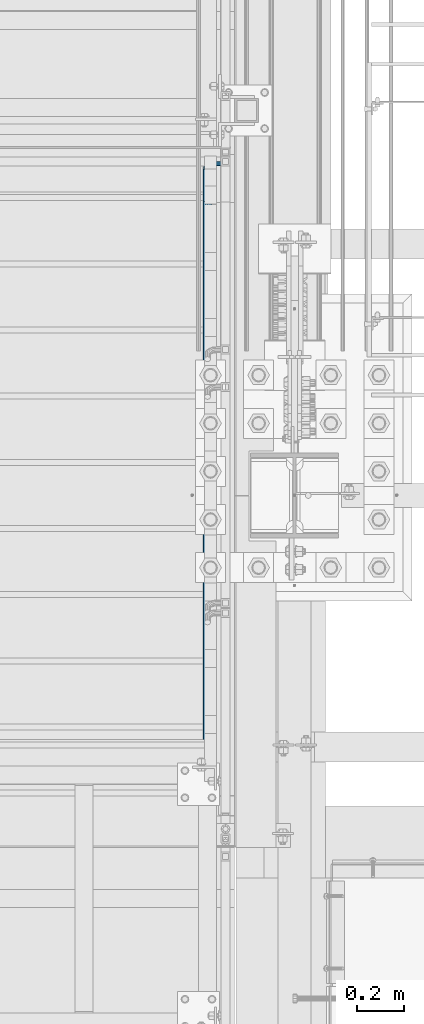
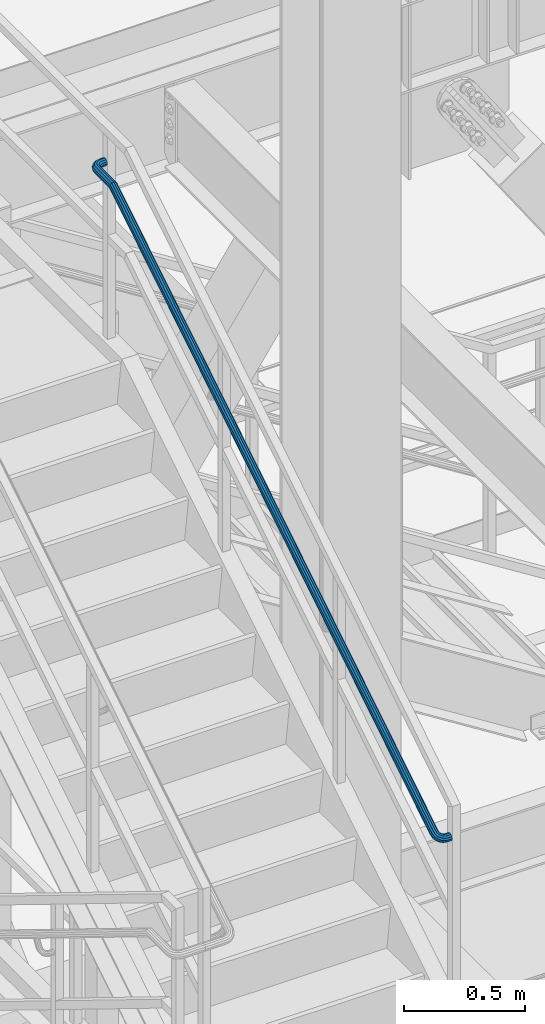
# One storey, part 1770 of 3843: 1 beam, 1 element without a shape of its own.
"""IFC2X3 building model written with IfcOpenShell, lengths in millimetres."""

from ifc_helpers import new_model, si_unit, frame, origin_with_axes, place, context, subcontext, project, spatial, faceted_brep, material, type_object, element, aggregate, save


model = new_model("IFC2X3")

# Units and contexts
model_context = context("Model", 3, precision=1e-05, world=origin_with_axes())
body_context = subcontext(model_context, "Body", "Model", "MODEL_VIEW")
ifc_project = project(units=[si_unit("LENGTHUNIT", "METRE", prefix="MILLI"), si_unit("AREAUNIT", "SQUARE_METRE"), si_unit("VOLUMEUNIT", "CUBIC_METRE"), si_unit("MASSUNIT", "GRAM", prefix="KILO"), si_unit("TIMEUNIT", "SECOND"), si_unit("PLANEANGLEUNIT", "RADIAN"), si_unit("SOLIDANGLEUNIT", "STERADIAN"), si_unit("THERMODYNAMICTEMPERATUREUNIT", "DEGREE_CELSIUS"), si_unit("LUMINOUSINTENSITYUNIT", "LUMEN")], contexts=[model_context])

# Site, building, storey
site_placement = place(None, origin_with_axes())
site = spatial("IfcSite", under=ifc_project, at=site_placement, CompositionType="ELEMENT")
building_placement = place(site_placement, origin_with_axes())
building = spatial("IfcBuilding", under=site, at=building_placement, Name="Undefined", CompositionType="ELEMENT")
storey_placement = place(building_placement, origin_with_axes())
storey = spatial("IfcBuildingStorey", under=building, at=storey_placement, Name="Undefined", CompositionType="ELEMENT", Elevation=0.0)

# Assembly, beam
assembly_placement = place(storey_placement, origin_with_axes())
assembly = element("IfcElementAssembly", 1, at=assembly_placement, inside=storey, Name="RAIL", AssemblyPlace="NOTDEFINED", PredefinedType="RIGID_FRAME")
ifc_material = material(Name="STEEL/A513")
beam_type = type_object("IfcBeamType", PredefinedType="NOTDEFINED")
beam_placement = place(assembly_placement, frame((55619.65, 18859.5000010295, 35928.2230266372), z_axis=(0.0, 0.0, 1.0), x_axis=(-1.0, 0.0, 0.0)))
beam = element("IfcBeam", 2, at=beam_placement, type_object=beam_type, material=ifc_material, Name="GRAB RAIL", context=body_context, shape_type="Brep", body=[
    faceted_brep([(0.0, -19.0500000000029, 0.0), (0.0, -16.4977839420972, -9.52500000000146), (19.0500015258804, -16.4977839420972, -9.52500000000146), (19.0500015258804, -19.0500000000029, 0.0), (0.0, -9.52500000000146, -16.4977839420972), (19.0500015258804, -9.52500000000146, -16.4977839420972), (0.0, 0.0, -19.0499989999989), (19.0500015258804, 0.0, -19.0500000000029), (0.0, 9.52500000000146, -16.4977839420972), (19.0500015258804, 9.52500000000146, -16.4977839420972), (0.0, 16.4977839420972, -9.52500000000146), (19.0500015258804, 16.4977839420972, -9.52500000000146), (0.0, 19.0500000000029, 0.0), (19.0500015258804, 19.0500000000029, 0.0), (0.0, 16.4977839420972, 9.52500000000146), (19.0500015258804, 16.4977839420972, 9.52500000000146), (0.0, 9.52500000000146, 16.4977839420972), (19.0500015258804, 9.52500000000146, 16.4977839420972), (0.0, 0.0, 19.0499989999989), (19.0500015258804, 0.0, 19.0500000000029), (0.0, -9.52500000000146, 16.4977839420972), (19.0500015258804, -9.52500000000146, 16.4977839420972), (0.0, -16.4977839420972, 9.52500000000146), (19.0500015258804, -16.4977839420972, 9.52500000000146), (0.0, -15.875, 0.0), (0.0, -13.7481532850798, 7.9375), (19.0500015258804, -13.7481532850798, 7.9375), (19.0500015258804, -15.875, 0.0), (0.0, -7.9375, 13.7481532850798), (19.0500015258804, -7.9375, 13.7481532850798), (0.0, 0.0, 15.875), (19.0500015258804, 0.0, 15.875), (0.0, 7.9375, 13.7481532850798), (19.0500015258804, 7.9375, 13.7481532850798), (0.0, 13.7481532850798, 7.9375), (19.0500015258804, 13.7481532850798, 7.9375), (0.0, 15.875, 0.0), (19.0500015258804, 15.875, 0.0), (0.0, 13.7481532850798, -7.9375), (19.0500015258804, 13.7481532850798, -7.9375), (0.0, 7.9375, -13.7481532850798), (19.0500015258804, 7.9375, -13.7481532850798), (0.0, 0.0, -15.875), (19.0500015258804, 0.0, -15.875), (0.0, -7.9375, -13.7481532850798), (19.0500015258804, -7.9375, -13.7481532850798), (0.0, -13.7481532850798, -7.9375), (19.0500015258804, -13.7481532850798, -7.9375), (25.8298748692396, -19.9609130194985, 0.568630552115792), (24.9402688023329, -17.2891735269295, 10.0190189534405), (25.6270827899934, -10.4086667958763, 17.0494062455109), (27.7062855788754, -1.16301904843931, 19.7760058309432), (30.6207564607903, 7.97040586794901, 17.4682275527448), (33.5895653165717, 14.544314122817, 10.7444387368523), (35.817222210826, 16.7972323081558, 1.40627316657628), (36.7068282777327, 14.1254928155868, -8.04411523474118), (36.0200142900721, 7.24498608453359, -15.0745025268116), (33.9408115011975, -2.0006616628998, -17.8011021122438), (31.0263406192753, -11.1340865792918, -15.4933238340454), (28.0575317634939, -17.7079948341598, -8.76953501816024), (35.7262816547809, 11.5076039537125, -6.53885405239271), (34.9849432656993, 13.7340535308504, 1.33646961537306), (33.1285625204837, 11.8566217097359, 9.11827425727097), (30.6545551406598, 6.37836483067804, 14.7214316038444), (28.2258294057319, -1.23282259964617, 16.6445801690134), (26.4931604150042, -8.93752905584188, 14.3724138478137), (25.9208154252847, -14.6712846650553, 8.51375777109206), (26.6621538143736, -16.8977342421931, 0.63843410332629), (28.5185345595892, -15.0203024210787, -7.14337053857162), (30.9925419394058, -9.54204554202079, -12.746527885145), (33.4212676743336, -1.93085811169658, -14.669676450314), (35.1539366650686, 5.77384834449913, -12.3975101291217), (46.7058953003507, 8.8751239015146, 14.283387787531), (50.9431505110551, 10.2594458302447, 5.48743685069348), (41.0588852844958, 3.4587979769276, 20.2845646025962), (35.5152322368958, -4.53823178607854, 21.8829568146684), (31.5603535147675, -12.9731677206655, 18.6502765213299), (30.2539556778793, -19.5858755549489, 11.4527177965647), (31.9460869716058, -22.6044855649452, 2.21886068815365), (36.1833421823176, -21.2201636362188, -6.57709024868382), (41.8303521981725, -15.8038377116318, -12.5782670637491), (47.3740052457724, -7.80680794862201, -14.1766592758213), (51.3288839678935, 0.628127985964966, -10.9439789824828), (52.635281804789, 7.24083582024468, -3.74642025771755), (49.6815064301336, -0.50531332292303, -8.47779102382628), (50.7701712942144, 5.00527653898098, -2.4798254198613), (46.3857741616957, -7.53442660174187, -11.1716912682823), (41.7660632886982, -14.1986180709173, -9.83969775822334), (37.0602216088155, -18.7122230080713, -4.83871707900107), (33.5291755998915, -19.8658246153464, 2.49124203503015), (32.1190661884539, -17.3503162736815, 10.1861229587084), (33.2077310525274, -11.8397264117812, 16.1840885626807), (36.5034633209652, -4.81061313295868, 18.8779888071294), (41.12317419397, 1.85357833621674, 17.5459952970705), (45.8290158738455, 6.36718327337076, 12.5450146178482), (49.3600618827695, 7.52078488064581, 5.21505550381698), (57.115073711524, 0.0451531166363566, 19.7954301616264), (62.9471551759634, 0.0766046581811679, 11.843998315795), (49.3426312209849, -3.56819605845521, 24.6711123986461), (41.7124473929071, -9.79524887365551, 25.1646099088903), (36.2690238221185, -16.9674715559122, 21.1436904330258), (34.47092145848, -23.1630728295713, 13.6857560974386), (36.7999403782305, -26.7219463367328, 4.78915438455442), (42.6320218426699, -26.6904947951916, -3.16227746127697), (50.4044643332018, -23.0771456201001, -8.03795969829662), (58.0346481612869, -16.8500928048961, -8.53145720854081), (63.4780717320682, -9.67787012263943, -4.51053773267631), (65.2761740957139, -3.48226884898395, 2.94739660291089), (61.2106510729063, -10.2853369087461, -2.37268538553326), (62.709069709279, -5.12233584736532, 3.84225989411789), (56.6744647639207, -16.2621891439594, -5.72345161542034), (50.3159782405201, -21.4513998232942, -5.31220369022049), (43.8389428317387, -24.4625241358699, -1.24913515937078), (38.9788749447034, -24.4887337538239, 5.3770580454875), (37.038025844915, -21.5230058311863, 12.7908928062243), (38.5364444812803, -16.3600047698055, 19.0058380858827), (43.072630790266, -10.3831525345922, 22.3566043157698), (49.4311173136666, -5.19394185525744, 21.9453563905699), (55.908152722448, -2.18281754268173, 17.8822878597202), (60.7682206094833, -2.15660792472772, 11.2560946548547), (63.7981776422239, -11.0812591693903, 26.7410087469252), (70.654200592151, -12.7545237661107, 19.8537330369218), (54.6611235017626, -12.4227251020857, 30.198485079738), (45.691304448912, -16.4194768508569, 29.2997340441289), (39.2921762551268, -22.0005880122771, 24.2855752542891), (37.1783801522106, -27.6706043577688, 16.4995485086838), (39.9163060988867, -31.91024958649, 8.02791338603129), (46.7723290488211, -33.5835141832104, 1.14063767602784), (55.9093831892824, -32.2420482505149, -2.31683865678497), (64.879202242133, -28.2452965017437, -1.4180876211758), (71.2783304359109, -22.6641853403235, 3.59607116865664), (73.3921265388344, -16.9941689948319, 11.3820979142693), (68.6128175875128, -22.608885562986, 5.32019650912844), (70.3743143399479, -17.8838719417436, 11.8085521304747), (63.280210759367, -27.2598115308356, 1.14173085093353), (55.8053615486569, -30.5904379881467, 0.392771654594981), (48.1911497649344, -31.7083262653941, 3.27400193193898), (42.4777973066593, -30.3139391014593, 9.01339835693943), (40.1961923510971, -26.780901410857, 16.0730942924783), (41.9576891035249, -22.0558877896146, 22.5614499138246), (47.290295931678, -17.404961821765, 26.7399155720195), (54.7651451423881, -14.0743353644539, 27.4888747683581), (62.3793569261034, -12.9564470872065, 24.6076444910141), (68.0927093843784, -14.3508342511414, 18.8682480660136), (57.806248953726, -42.401421077775, 4.02507287184562), (48.1989816842106, -41.2244850360839, 5.91045584942913), (67.237674846052, -40.8769771062507, 6.46714330929535), (73.9661164098725, -37.0596266525899, 12.5823163601963), (76.1886931618355, -31.9722256880741, 20.7320363439794), (73.3098674561406, -26.9779391927186, 28.7325923724566), (66.1010183157778, -23.4149821997271, 34.4402419187973), (56.4937510462623, -22.238046158036, 36.3256248963735), (47.0623251539364, -23.7624901295603, 33.8835544589238), (40.3338835901159, -27.5798405832211, 27.7683814080228), (38.1113068381528, -32.6672415477406, 19.6186614242397), (40.9901325438477, -37.6615280430924, 11.6181053957625), (71.1634303415558, -36.2696444801404, 13.8478217808515), (73.015577634862, -32.0301436763766, 20.639255100672), (65.5563957050472, -39.4507698581947, 8.75184423843166), (57.6968741281016, -40.7211398344662, 6.71678554055688), (49.6908180701794, -39.7403597997218, 8.28793802187283), (43.68344378654, -36.7712289722294, 13.0443126438186), (41.2844223651264, -32.6093235594344, 19.7114426675471), (43.1365696584326, -28.3698227556706, 26.5028759873676), (48.7436042949412, -25.1886973776163, 31.5988535297874), (56.6031258718867, -23.9183274013485, 33.6339122276622), (64.609181929809, -24.8991074360893, 32.0627597463463), (70.6165562134483, -27.8682382635816, 27.3063851244005), (48.1989816842106, -2696.25353190033, 1663.29222610786), (40.9901325438477, -2692.69057490734, 1668.9998756542), (57.806248953726, -2697.43046794202, 1661.40684313028), (67.237674846052, -2695.9060239705, 1663.84891356773), (73.9661164098725, -2692.08867351683, 1669.96408661863), (76.1886931618355, -2687.00127255231, 1678.11380660241), (73.3098674561406, -2682.00698605696, 1686.11436263089), (66.1010183157778, -2678.44402906396, 1691.82201217723), (56.4937510462623, -2677.26709302227, 1693.70739515481), (47.0623251539364, -2678.7915369938, 1691.26532471736), (40.3338835901159, -2682.60888744746, 1685.15015166646), (38.1113068381528, -2687.69628841198, 1677.00043168267), (41.2844223651264, -2687.63837042368, 1677.09321292599), (43.68344378654, -2691.80027583647, 1670.42608290225), (43.1365696584326, -2683.39886961991, 1683.88464624581), (48.7436042949412, -2680.21774424186, 1688.98062378822), (56.6031258718867, -2678.94737426559, 1691.0156824861), (64.609181929809, -2679.92815430033, 1689.44453000478), (70.6165562134483, -2682.89728512782, 1684.68815538284), (73.015577634862, -2687.05919054062, 1678.02102535911), (71.1634303415558, -2691.29869134438, 1671.22959203928), (65.5563957050472, -2694.47981672244, 1666.13361449687), (57.6968741281016, -2695.75018669871, 1664.09855579899), (49.6908180701794, -2694.76940666396, 1665.66970828031), (48.1989816842106, -2697.2178401868, 1663.89418825091), (40.9901325438477, -2695.29013254061, 1670.62262981473), (57.806248953726, -2697.8546114448, 1661.67161149895), (67.237674846052, -2697.02982397028, 1664.55043720464), (73.9661164098725, -2694.96447890095, 1671.759286345), (76.1886931618355, -2692.21198378023, 1681.36655361452), (73.3098674561406, -2689.5098674529, 1690.79797950685), (66.1010183157778, -2687.58215980671, 1697.52642107067), (56.4937510462623, -2686.94538854871, 1699.74899782263), (47.0623251539364, -2687.77017602323, 1696.87017211693), (40.3338835901159, -2689.83552109256, 1689.66132297657), (38.1113068381528, -2692.58801621328, 1680.05405570706), (41.2844223651264, -2692.55668017719, 1680.16343053268), (43.68344378654, -2694.8084437833, 1672.30390895574), (43.1365696584326, -2690.26293424326, 1688.1694865906), (48.7436042949412, -2688.54181335216, 1694.17686087424), (56.6031258718867, -2687.85449045672, 1696.57588229566), (64.609181929809, -2688.38513317172, 1694.72373500236), (70.6165562134483, -2689.99155621021, 1689.11670036584), (73.015577634862, -2692.24331981632, 1681.2571787889), (71.1634303415558, -2694.53706575025, 1673.25112273097), (65.5563957050472, -2696.25818664136, 1667.24374844733), (57.6968741281016, -2696.9455095368, 1664.84472702592), (49.6908180701794, -2696.41486682179, 1666.69687431922), (48.1989816842106, -2698.3546114448, 1663.89418825091), (40.9901325438477, -2698.3546114448, 1670.62262981473), (57.806248953726, -2698.3546114448, 1661.67161149895), (67.237674846052, -2698.3546114448, 1664.55043720464), (73.9661164098725, -2698.3546114448, 1671.75928634501), (76.1886931618355, -2698.3546114448, 1681.36655361452), (73.3098674561406, -2698.3546114448, 1690.79797950685), (66.1010183157778, -2698.3546114448, 1697.52642107067), (56.4937510462623, -2698.3546114448, 1699.74899782263), (47.0623251539364, -2698.3546114448, 1696.87017211693), (40.3338835901159, -2698.3546114448, 1689.66132297656), (38.1113068381528, -2698.3546114448, 1680.05405570706), (41.2844223651264, -2698.3546114448, 1680.16343053267), (43.68344378654, -2698.3546114448, 1672.30390895574), (43.1365696584326, -2698.3546114448, 1688.1694865906), (48.7436042949412, -2698.3546114448, 1694.17686087424), (56.6031258718795, -2698.3546114448, 1696.57588229566), (64.609181929809, -2698.3546114448, 1694.72373500235), (70.6165562134483, -2698.3546114448, 1689.11670036584), (73.015577634862, -2698.3546114448, 1681.2571787889), (71.1634303415558, -2698.3546114448, 1673.25112273097), (65.5563957050472, -2698.3546114448, 1667.24374844733), (57.6968741281089, -2698.3546114448, 1664.84472702592), (49.6908180701794, -2698.3546114448, 1666.69687431923), (48.1989816842106, -2819.40000050106, 1663.89418825091), (40.990132543855, -2819.40000050106, 1670.62262981472), (57.806248953726, -2819.40000050106, 1661.67161149895), (67.237674846052, -2819.40000050106, 1664.55043720464), (73.9661164098725, -2819.40000050106, 1671.75928634501), (76.1886931618355, -2819.40000050106, 1681.36655361452), (73.3098674561406, -2819.40000050106, 1690.79797950685), (66.1010183157778, -2819.40000050106, 1697.52642107067), (56.4937510462623, -2819.40000050106, 1699.74899782263), (47.0623251539364, -2819.40000050106, 1696.87017211693), (40.3338835901159, -2819.40000050106, 1689.66132297656), (38.1113068381528, -2819.40000050106, 1680.05405570706), (41.2844223651264, -2819.40000050106, 1680.16343053267), (43.68344378654, -2819.40000050106, 1672.30390895574), (43.1365696584326, -2819.40000050106, 1688.1694865906), (48.7436042949412, -2819.40000050106, 1694.17686087424), (56.6031258718795, -2819.40000050106, 1696.57588229566), (64.609181929809, -2819.40000050106, 1694.72373500235), (70.6165562134483, -2819.40000050106, 1689.11670036584), (73.015577634862, -2819.40000050106, 1681.2571787889), (71.1634303415558, -2819.40000050106, 1673.25112273097), (65.5563957050472, -2819.40000050106, 1667.24374844733), (57.6968741281089, -2819.40000050106, 1664.84472702592), (49.6908180701794, -2819.40000050106, 1666.69687431923), (39.9163060988867, -2826.17987384443, 1670.62262981472), (37.1783801522106, -2825.29026777753, 1680.05405570705), (39.2921762551341, -2825.97708176519, 1689.66132297656), (45.691304448912, -2828.05628455407, 1696.87017211693), (54.6611235017626, -2830.97075543599, 1699.74899782263), (63.7981776422239, -2833.93956429177, 1697.52642107067), (70.654200592151, -2836.16722118603, 1690.79797950685), (73.3921265388271, -2837.05682725293, 1681.36655361453), (71.2783304359109, -2836.37001326527, 1671.75928634502), (64.8792022421258, -2834.29081047639, 1664.55043720465), (55.9093831892751, -2831.37633959447, 1661.67161149895), (46.7723290488211, -2828.40753073869, 1663.89418825091), (70.3743143399479, -2836.07628062998, 1681.2571787889), (68.0927093843784, -2835.3349422409, 1689.11670036584), (62.3793569261034, -2833.47856149568, 1694.72373500236), (54.7651451423953, -2831.00455411587, 1696.57588229566), (47.2902959316853, -2828.57582838093, 1694.17686087424), (41.9576891035322, -2826.8431593902, 1688.1694865906), (40.1961923510971, -2826.27081440048, 1680.16343053267), (42.4777973066593, -2827.01215278957, 1672.30390895574), (48.1911497649344, -2828.86853353478, 1666.69687431923), (55.8053615486497, -2831.3425409146, 1664.84472702593), (63.2802107593598, -2833.77126664953, 1667.24374844734), (68.6128175875128, -2835.50393564026, 1673.25112273098), (57.115073711524, -2847.05589427555, 1697.52642107067), (62.9471551759634, -2851.29314948625, 1690.79797950685), (49.3426312209922, -2841.4088842597, 1699.74899782263), (41.7124473929071, -2835.8652312121, 1696.87017211693), (36.2690238221257, -2831.91035248997, 1689.66132297656), (34.47092145848, -2830.60395465308, 1680.05405570706), (36.7999403782305, -2832.2960859468, 1670.62262981473), (42.6320218426699, -2836.53334115751, 1663.89418825091), (50.4044643332018, -2842.18035117336, 1661.67161149895), (58.0346481612869, -2847.72400422096, 1664.55043720465), (63.4780717320682, -2851.67888294308, 1671.75928634502), (65.2761740957139, -2852.98528077998, 1681.36655361453), (61.2106510729063, -2850.03150540532, 1673.25112273098), (62.709069709279, -2851.12017026941, 1681.2571787889), (56.6744647639207, -2846.73577313689, 1667.24374844734), (50.3159782405201, -2842.11606226389, 1664.84472702593), (43.8389428317387, -2837.41022058401, 1666.69687431923), (38.9788749447107, -2833.87917457509, 1672.30390895574), (37.038025844915, -2832.46906516365, 1680.16343053267), (38.5364444812876, -2833.55773002773, 1688.1694865906), (43.0726307902733, -2836.85346229617, 1694.17686087424), (49.4311173136739, -2841.47317316917, 1696.57588229566), (55.9081527224553, -2846.17901484904, 1694.72373500236), (60.7682206094833, -2849.71006085797, 1689.11670036584), (46.7058953003434, -2857.46507268674, 1697.52642107067), (50.9431505110479, -2863.29715415117, 1690.79797950685), (41.0588852844885, -2849.6926301962, 1699.74899782263), (35.5152322368958, -2842.06244636812, 1696.87017211693), (31.5603535147675, -2836.61902279733, 1689.66132297657), (30.2539556778793, -2834.82092043368, 1680.05405570706), (31.9460869716058, -2837.14993935343, 1670.62262981473), (36.1833421823103, -2842.98202081787, 1663.89418825092), (41.8303521981579, -2850.7544633084, 1661.67161149895), (47.3740052457579, -2858.38464713649, 1664.55043720465), (51.3288839678862, -2863.82807070727, 1671.75928634502), (52.6352818047744, -2865.62617307092, 1681.36655361453), (49.6815064301263, -2861.56065004811, 1673.25112273098), (50.7701712941998, -2863.05906868448, 1681.25717878891), (46.3857741616885, -2857.02446373912, 1667.24374844734), (41.7660632886909, -2850.66597721572, 1664.84472702593), (37.0602216088082, -2844.18894180694, 1666.69687431923), (33.5291755998915, -2839.32887391991, 1672.30390895574), (32.1190661884539, -2837.38802482012, 1680.16343053268), (33.2077310525274, -2838.88644345649, 1688.1694865906), (36.5034633209652, -2843.42262976548, 1694.17686087424), (41.1231741939628, -2849.78111628888, 1696.57588229566), (45.8290158738382, -2856.25815169766, 1694.72373500236), (49.3600618827622, -2861.11821958469, 1689.11670036584), (33.5895653165644, -2864.14817661744, 1697.52642107067), (35.8172222108187, -2871.00419956737, 1690.79797950685), (30.620756460783, -2855.01112247698, 1699.74899782263), (27.7062855788681, -2846.04130342413, 1696.87017211693), (25.6270827899934, -2839.64217523034, 1689.66132297657), (24.9402688023329, -2837.52837912742, 1680.05405570706), (25.8298748692323, -2840.2663050741, 1670.62262981473), (28.0575317634939, -2847.12232802402, 1663.89418825092), (31.026340619268, -2856.25938216448, 1661.67161149895), (33.9408115011902, -2865.22920121733, 1664.55043720465), (36.0200142900649, -2871.62832941112, 1671.75928634502), (36.7068282777254, -2873.74212551404, 1681.36655361453), (35.1539366650613, -2868.96281656272, 1673.25112273098), (35.7262816547736, -2870.72431331516, 1681.25717878891), (33.4212676743264, -2863.63020973457, 1667.24374844734), (30.9925419393985, -2856.15536052386, 1664.84472702593), (28.5185345595819, -2848.54114874014, 1666.69687431923), (26.6621538143663, -2842.82779628187, 1672.30390895574), (25.9208154252774, -2840.5461913263, 1680.16343053268), (26.493160414997, -2842.30768807874, 1688.16948659061), (28.2258294057319, -2847.64029490689, 1694.17686087424), (30.6545551406598, -2855.11514411761, 1696.57588229566), (33.1285625204764, -2862.72935590132, 1694.72373500236), (34.9849432656847, -2868.4427083596, 1689.11670036585), (19.0500015258731, -2858.15624792893, 1661.67161149895), (19.0500015258658, -2848.54898065942, 1663.89418825092), (19.0500015258731, -2867.58767382126, 1664.55043720466), (19.0500015258731, -2874.31611538508, 1671.75928634502), (19.0500015258658, -2876.53869213705, 1681.36655361453), (19.0500015258658, -2873.65986643136, 1690.79797950685), (19.0500015258585, -2866.45101729099, 1697.52642107067), (19.0500015258585, -2856.84375002148, 1699.74899782264), (19.0500015258585, -2847.41232412916, 1696.87017211693), (19.0500015258658, -2840.68388256533, 1689.66132297657), (19.0500015258658, -2838.46130581337, 1680.05405570706), (19.0500015258731, -2841.34013151904, 1670.62262981473), (19.0500015258658, -2871.51342931676, 1673.25112273098), (19.0500015258658, -2873.36557661007, 1681.25717878891), (19.0500015258731, -2865.90639468025, 1667.24374844734), (19.0500015258731, -2858.04687310331, 1664.84472702593), (19.0500015258658, -2850.04081704538, 1666.69687431923), (19.0500015258731, -2844.03344276173, 1672.30390895574), (19.0500015258658, -2841.63442134034, 1680.16343053269), (19.0500015258658, -2843.48656863365, 1688.16948659061), (19.0500015258585, -2849.09360327016, 1694.17686087425), (19.0500015258585, -2856.9531248471, 1696.57588229566), (19.0500015258585, -2864.95918090503, 1694.72373500236), (19.0500015258658, -2870.96655518866, 1689.11670036585), (0.0, -2848.5489806594, 1663.89418825091), (0.0, -2841.34013151904, 1670.62262981473), (0.0, -2858.15624792892, 1661.67161149895), (0.0, -2867.58767382124, 1664.55043720464), (0.0, -2874.31611538506, 1671.75928634501), (0.0, -2876.53869213702, 1681.36655361452), (0.0, -2873.65986643132, 1690.79797950685), (0.0, -2866.45101729096, 1697.52642107067), (0.0, -2856.84375002145, 1699.74899782263), (0.0, -2847.41232412912, 1696.87017211693), (0.0, -2840.6838825653, 1689.66132297656), (0.0, -2838.46130581334, 1680.05405570706), (0.0, -2841.63442134031, 1680.16343053267), (0.0, -2844.03344276173, 1672.30390895574), (0.0, -2843.48656863362, 1688.1694865906), (0.0, -2849.09360327013, 1694.17686087424), (0.0, -2856.95312484707, 1696.57588229566), (0.0, -2864.959180905, 1694.72373500235), (0.0, -2870.96655518864, 1689.11670036584), (0.0, -2873.36557661005, 1681.2571787889), (0.0, -2871.51342931675, 1673.25112273097), (0.0, -2865.90639468023, 1667.24374844733), (0.0, -2858.04687310329, 1664.84472702592), (0.0, -2850.04081704537, 1666.69687431923)], [[[0, 1, 2, 3]], [[1, 4, 5, 2]], [[4, 6, 7, 5]], [[6, 8, 9, 7]], [[8, 10, 11, 9]], [[10, 12, 13, 11]], [[12, 14, 15, 13]], [[14, 16, 17, 15]], [[16, 18, 19, 17]], [[18, 20, 21, 19]], [[20, 22, 23, 21]], [[22, 0, 3, 23]], [[24, 25, 26, 27]], [[25, 28, 29, 26]], [[28, 30, 31, 29]], [[30, 32, 33, 31]], [[32, 34, 35, 33]], [[34, 36, 37, 35]], [[36, 38, 39, 37]], [[38, 40, 41, 39]], [[40, 42, 43, 41]], [[42, 44, 45, 43]], [[44, 46, 47, 45]], [[46, 24, 27, 47]], [[22, 20, 18, 16, 14, 12, 10, 8, 6, 4, 1, 0], [46, 44, 42, 40, 38, 36, 34, 32, 30, 28, 25, 24]], [[23, 3, 48, 49]], [[21, 23, 49, 50]], [[19, 21, 50, 51]], [[17, 19, 51, 52]], [[15, 17, 52, 53]], [[13, 15, 53, 54]], [[11, 13, 54, 55]], [[9, 11, 55, 56]], [[7, 9, 56, 57]], [[5, 7, 57, 58]], [[2, 5, 58, 59]], [[3, 2, 59, 48]], [[37, 39, 60, 61]], [[35, 37, 61, 62]], [[33, 35, 62, 63]], [[31, 33, 63, 64]], [[29, 31, 64, 65]], [[26, 29, 65, 66]], [[27, 26, 66, 67]], [[47, 27, 67, 68]], [[45, 47, 68, 69]], [[43, 45, 69, 70]], [[41, 43, 70, 71]], [[39, 41, 71, 60]], [[53, 72, 73, 54]], [[52, 74, 72, 53]], [[51, 75, 74, 52]], [[50, 76, 75, 51]], [[49, 77, 76, 50]], [[48, 78, 77, 49]], [[59, 79, 78, 48]], [[58, 80, 79, 59]], [[57, 81, 80, 58]], [[56, 82, 81, 57]], [[55, 83, 82, 56]], [[54, 73, 83, 55]], [[71, 84, 85, 60]], [[70, 86, 84, 71]], [[69, 87, 86, 70]], [[68, 88, 87, 69]], [[67, 89, 88, 68]], [[66, 90, 89, 67]], [[65, 91, 90, 66]], [[64, 92, 91, 65]], [[63, 93, 92, 64]], [[62, 94, 93, 63]], [[61, 95, 94, 62]], [[60, 85, 95, 61]], [[72, 96, 97, 73]], [[74, 98, 96, 72]], [[75, 99, 98, 74]], [[76, 100, 99, 75]], [[77, 101, 100, 76]], [[78, 102, 101, 77]], [[79, 103, 102, 78]], [[80, 104, 103, 79]], [[81, 105, 104, 80]], [[82, 106, 105, 81]], [[83, 107, 106, 82]], [[73, 97, 107, 83]], [[84, 108, 109, 85]], [[86, 110, 108, 84]], [[87, 111, 110, 86]], [[88, 112, 111, 87]], [[89, 113, 112, 88]], [[90, 114, 113, 89]], [[91, 115, 114, 90]], [[92, 116, 115, 91]], [[93, 117, 116, 92]], [[94, 118, 117, 93]], [[95, 119, 118, 94]], [[85, 109, 119, 95]], [[96, 120, 121, 97]], [[98, 122, 120, 96]], [[99, 123, 122, 98]], [[100, 124, 123, 99]], [[101, 125, 124, 100]], [[102, 126, 125, 101]], [[103, 127, 126, 102]], [[104, 128, 127, 103]], [[105, 129, 128, 104]], [[106, 130, 129, 105]], [[107, 131, 130, 106]], [[97, 121, 131, 107]], [[108, 132, 133, 109]], [[110, 134, 132, 108]], [[111, 135, 134, 110]], [[112, 136, 135, 111]], [[113, 137, 136, 112]], [[114, 138, 137, 113]], [[115, 139, 138, 114]], [[116, 140, 139, 115]], [[117, 141, 140, 116]], [[118, 142, 141, 117]], [[119, 143, 142, 118]], [[109, 133, 143, 119]], [[128, 144, 145, 127]], [[129, 146, 144, 128]], [[130, 147, 146, 129]], [[131, 148, 147, 130]], [[121, 149, 148, 131]], [[120, 150, 149, 121]], [[122, 151, 150, 120]], [[123, 152, 151, 122]], [[124, 153, 152, 123]], [[125, 154, 153, 124]], [[126, 155, 154, 125]], [[127, 145, 155, 126]], [[132, 156, 157, 133]], [[134, 158, 156, 132]], [[135, 159, 158, 134]], [[136, 160, 159, 135]], [[137, 161, 160, 136]], [[138, 162, 161, 137]], [[139, 163, 162, 138]], [[140, 164, 163, 139]], [[141, 165, 164, 140]], [[142, 166, 165, 141]], [[143, 167, 166, 142]], [[133, 157, 167, 143]], [[155, 145, 168, 169]], [[145, 144, 170, 168]], [[144, 146, 171, 170]], [[146, 147, 172, 171]], [[147, 148, 173, 172]], [[148, 149, 174, 173]], [[149, 150, 175, 174]], [[150, 151, 176, 175]], [[151, 152, 177, 176]], [[152, 153, 178, 177]], [[153, 154, 179, 178]], [[154, 155, 169, 179]], [[161, 162, 180, 181]], [[162, 163, 182, 180]], [[163, 164, 183, 182]], [[164, 165, 184, 183]], [[165, 166, 185, 184]], [[166, 167, 186, 185]], [[167, 157, 187, 186]], [[157, 156, 188, 187]], [[156, 158, 189, 188]], [[158, 159, 190, 189]], [[159, 160, 191, 190]], [[160, 161, 181, 191]], [[169, 168, 192, 193]], [[168, 170, 194, 192]], [[170, 171, 195, 194]], [[171, 172, 196, 195]], [[172, 173, 197, 196]], [[173, 174, 198, 197]], [[174, 175, 199, 198]], [[175, 176, 200, 199]], [[176, 177, 201, 200]], [[177, 178, 202, 201]], [[178, 179, 203, 202]], [[179, 169, 193, 203]], [[181, 180, 204, 205]], [[180, 182, 206, 204]], [[182, 183, 207, 206]], [[183, 184, 208, 207]], [[184, 185, 209, 208]], [[185, 186, 210, 209]], [[186, 187, 211, 210]], [[187, 188, 212, 211]], [[188, 189, 213, 212]], [[189, 190, 214, 213]], [[190, 191, 215, 214]], [[191, 181, 205, 215]], [[193, 192, 216, 217]], [[192, 194, 218, 216]], [[194, 195, 219, 218]], [[195, 196, 220, 219]], [[196, 197, 221, 220]], [[197, 198, 222, 221]], [[198, 199, 223, 222]], [[199, 200, 224, 223]], [[200, 201, 225, 224]], [[201, 202, 226, 225]], [[202, 203, 227, 226]], [[203, 193, 217, 227]], [[205, 204, 228, 229]], [[204, 206, 230, 228]], [[206, 207, 231, 230]], [[207, 208, 232, 231]], [[208, 209, 233, 232]], [[209, 210, 234, 233]], [[210, 211, 235, 234]], [[211, 212, 236, 235]], [[212, 213, 237, 236]], [[213, 214, 238, 237]], [[214, 215, 239, 238]], [[215, 205, 229, 239]], [[217, 216, 240, 241]], [[216, 218, 242, 240]], [[218, 219, 243, 242]], [[219, 220, 244, 243]], [[220, 221, 245, 244]], [[221, 222, 246, 245]], [[222, 223, 247, 246]], [[223, 224, 248, 247]], [[224, 225, 249, 248]], [[225, 226, 250, 249]], [[226, 227, 251, 250]], [[227, 217, 241, 251]], [[229, 228, 252, 253]], [[228, 230, 254, 252]], [[230, 231, 255, 254]], [[231, 232, 256, 255]], [[232, 233, 257, 256]], [[233, 234, 258, 257]], [[234, 235, 259, 258]], [[235, 236, 260, 259]], [[236, 237, 261, 260]], [[237, 238, 262, 261]], [[238, 239, 263, 262]], [[239, 229, 253, 263]], [[251, 241, 264, 265]], [[250, 251, 265, 266]], [[249, 250, 266, 267]], [[248, 249, 267, 268]], [[247, 248, 268, 269]], [[246, 247, 269, 270]], [[245, 246, 270, 271]], [[244, 245, 271, 272]], [[243, 244, 272, 273]], [[242, 243, 273, 274]], [[240, 242, 274, 275]], [[241, 240, 275, 264]], [[258, 259, 276, 277]], [[257, 258, 277, 278]], [[256, 257, 278, 279]], [[255, 256, 279, 280]], [[254, 255, 280, 281]], [[252, 254, 281, 282]], [[253, 252, 282, 283]], [[263, 253, 283, 284]], [[262, 263, 284, 285]], [[261, 262, 285, 286]], [[260, 261, 286, 287]], [[259, 260, 287, 276]], [[269, 288, 289, 270]], [[268, 290, 288, 269]], [[267, 291, 290, 268]], [[266, 292, 291, 267]], [[265, 293, 292, 266]], [[264, 294, 293, 265]], [[275, 295, 294, 264]], [[274, 296, 295, 275]], [[273, 297, 296, 274]], [[272, 298, 297, 273]], [[271, 299, 298, 272]], [[270, 289, 299, 271]], [[287, 300, 301, 276]], [[286, 302, 300, 287]], [[285, 303, 302, 286]], [[284, 304, 303, 285]], [[283, 305, 304, 284]], [[282, 306, 305, 283]], [[281, 307, 306, 282]], [[280, 308, 307, 281]], [[279, 309, 308, 280]], [[278, 310, 309, 279]], [[277, 311, 310, 278]], [[276, 301, 311, 277]], [[288, 312, 313, 289]], [[290, 314, 312, 288]], [[291, 315, 314, 290]], [[292, 316, 315, 291]], [[293, 317, 316, 292]], [[294, 318, 317, 293]], [[295, 319, 318, 294]], [[296, 320, 319, 295]], [[297, 321, 320, 296]], [[298, 322, 321, 297]], [[299, 323, 322, 298]], [[289, 313, 323, 299]], [[300, 324, 325, 301]], [[302, 326, 324, 300]], [[303, 327, 326, 302]], [[304, 328, 327, 303]], [[305, 329, 328, 304]], [[306, 330, 329, 305]], [[307, 331, 330, 306]], [[308, 332, 331, 307]], [[309, 333, 332, 308]], [[310, 334, 333, 309]], [[311, 335, 334, 310]], [[301, 325, 335, 311]], [[312, 336, 337, 313]], [[314, 338, 336, 312]], [[315, 339, 338, 314]], [[316, 340, 339, 315]], [[317, 341, 340, 316]], [[318, 342, 341, 317]], [[319, 343, 342, 318]], [[320, 344, 343, 319]], [[321, 345, 344, 320]], [[322, 346, 345, 321]], [[323, 347, 346, 322]], [[313, 337, 347, 323]], [[324, 348, 349, 325]], [[326, 350, 348, 324]], [[327, 351, 350, 326]], [[328, 352, 351, 327]], [[329, 353, 352, 328]], [[330, 354, 353, 329]], [[331, 355, 354, 330]], [[332, 356, 355, 331]], [[333, 357, 356, 332]], [[334, 358, 357, 333]], [[335, 359, 358, 334]], [[325, 349, 359, 335]], [[344, 360, 361, 343]], [[345, 362, 360, 344]], [[346, 363, 362, 345]], [[347, 364, 363, 346]], [[337, 365, 364, 347]], [[336, 366, 365, 337]], [[338, 367, 366, 336]], [[339, 368, 367, 338]], [[340, 369, 368, 339]], [[341, 370, 369, 340]], [[342, 371, 370, 341]], [[343, 361, 371, 342]], [[348, 372, 373, 349]], [[350, 374, 372, 348]], [[351, 375, 374, 350]], [[352, 376, 375, 351]], [[353, 377, 376, 352]], [[354, 378, 377, 353]], [[355, 379, 378, 354]], [[356, 380, 379, 355]], [[357, 381, 380, 356]], [[358, 382, 381, 357]], [[359, 383, 382, 358]], [[349, 373, 383, 359]], [[371, 361, 384, 385]], [[361, 360, 386, 384]], [[360, 362, 387, 386]], [[362, 363, 388, 387]], [[363, 364, 389, 388]], [[364, 365, 390, 389]], [[365, 366, 391, 390]], [[366, 367, 392, 391]], [[367, 368, 393, 392]], [[368, 369, 394, 393]], [[369, 370, 395, 394]], [[370, 371, 385, 395]], [[377, 378, 396, 397]], [[378, 379, 398, 396]], [[379, 380, 399, 398]], [[380, 381, 400, 399]], [[381, 382, 401, 400]], [[382, 383, 402, 401]], [[383, 373, 403, 402]], [[373, 372, 404, 403]], [[372, 374, 405, 404]], [[374, 375, 406, 405]], [[375, 376, 407, 406]], [[376, 377, 397, 407]], [[386, 387, 388, 389, 390, 391, 392, 393, 394, 395, 385, 384], [398, 399, 400, 401, 402, 403, 404, 405, 406, 407, 397, 396]]]),
])
aggregate(assembly, [beam])

save(model, "model.ifc")
